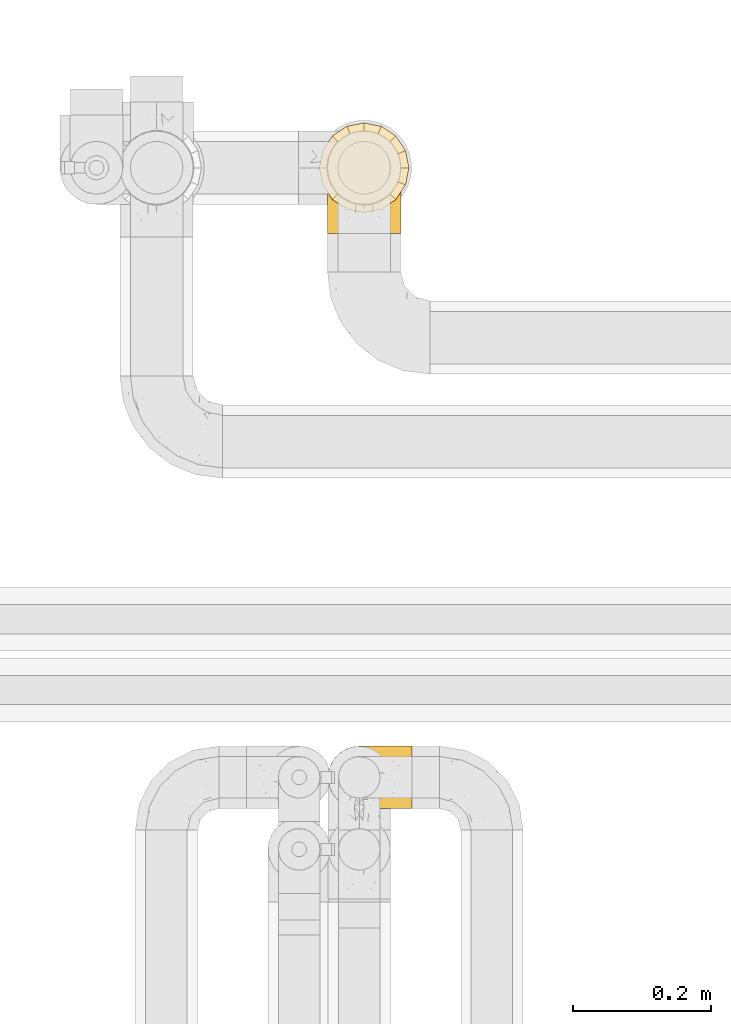
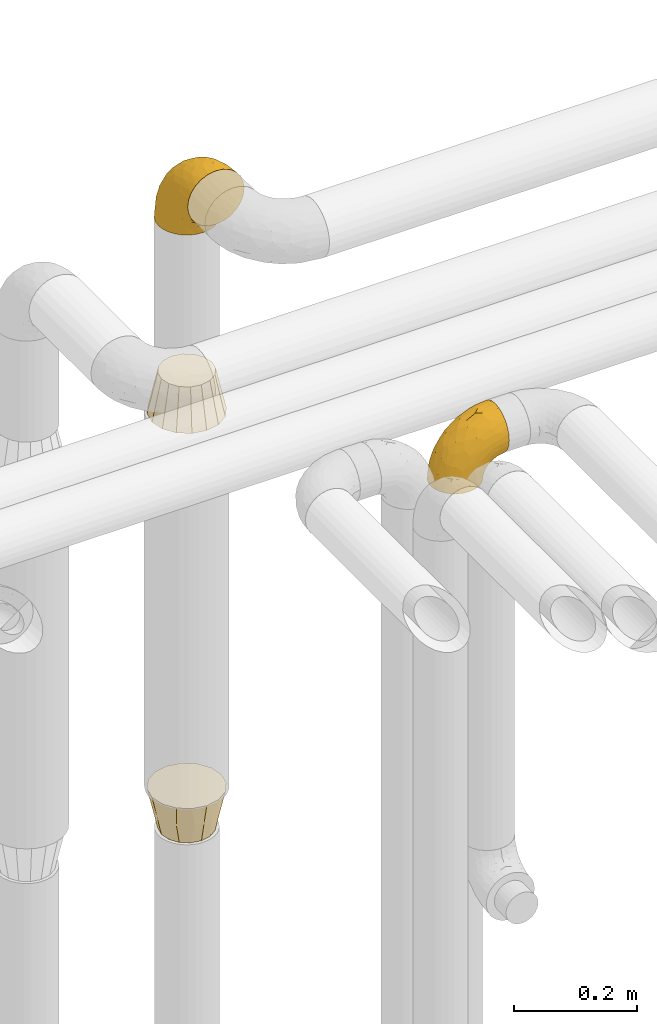
# One storey, part 324 of 827: 4 coverings.
"""IFC2X3 building model written with IfcOpenShell, lengths in millimetres."""

from ifc_helpers import new_model, entity, si_unit, converted_unit, derived_unit, direction, frame, origin, place, context, subcontext, project, spatial, faceted_brep, element, save


model = new_model("IFC2X3")

# Units and contexts
model_context = context("Model", 3, precision=0.01, world=origin(), true_north=direction((6.12303176911189e-17, 1.0)))
body_context = subcontext(model_context, "Body", "Model", "MODEL_VIEW")
ifc_project = project(units=[si_unit("LENGTHUNIT", "METRE", prefix="MILLI"), si_unit("AREAUNIT", "SQUARE_METRE"), si_unit("VOLUMEUNIT", "CUBIC_METRE"), converted_unit("PLANEANGLEUNIT", "DEGREE", entity("IfcRatioMeasure", 0.0174532925199433), si_unit("PLANEANGLEUNIT", "RADIAN"), dimensions=[0, 0, 0, 0, 0, 0, 0]), si_unit("MASSUNIT", "GRAM", prefix="KILO"), derived_unit("MASSDENSITYUNIT", [(si_unit("MASSUNIT", "GRAM", prefix="KILO"), 1), (si_unit("LENGTHUNIT", "METRE"), -3)]), derived_unit("MOMENTOFINERTIAUNIT", [(si_unit("LENGTHUNIT", "METRE"), 4)]), si_unit("TIMEUNIT", "SECOND"), si_unit("FREQUENCYUNIT", "HERTZ"), si_unit("THERMODYNAMICTEMPERATUREUNIT", "DEGREE_CELSIUS"), derived_unit("THERMALTRANSMITTANCEUNIT", [(si_unit("MASSUNIT", "GRAM", prefix="KILO"), 1), (si_unit("THERMODYNAMICTEMPERATUREUNIT", "KELVIN"), -1), (si_unit("TIMEUNIT", "SECOND"), -3)]), derived_unit("VOLUMETRICFLOWRATEUNIT", [(si_unit("LENGTHUNIT", "METRE"), 3), (si_unit("TIMEUNIT", "SECOND"), -1)]), derived_unit("MASSFLOWRATEUNIT", [(si_unit("MASSUNIT", "GRAM", prefix="KILO"), 1), (si_unit("TIMEUNIT", "SECOND"), -1)]), derived_unit("ROTATIONALFREQUENCYUNIT", [(si_unit("TIMEUNIT", "SECOND"), -1)]), si_unit("ELECTRICCURRENTUNIT", "AMPERE"), si_unit("ELECTRICVOLTAGEUNIT", "VOLT"), si_unit("POWERUNIT", "WATT"), si_unit("FORCEUNIT", "NEWTON", prefix="KILO"), si_unit("ILLUMINANCEUNIT", "LUX"), si_unit("LUMINOUSFLUXUNIT", "LUMEN"), si_unit("LUMINOUSINTENSITYUNIT", "CANDELA"), derived_unit("USERDEFINED", [(si_unit("MASSUNIT", "GRAM", prefix="KILO"), -1), (si_unit("LENGTHUNIT", "METRE"), -2), (si_unit("TIMEUNIT", "SECOND"), 3), (si_unit("LUMINOUSFLUXUNIT", "LUMEN"), 1)]), derived_unit("LINEARVELOCITYUNIT", [(si_unit("LENGTHUNIT", "METRE"), 1), (si_unit("TIMEUNIT", "SECOND"), -1)]), si_unit("PRESSUREUNIT", "PASCAL"), derived_unit("USERDEFINED", [(si_unit("LENGTHUNIT", "METRE"), -2), (si_unit("MASSUNIT", "GRAM", prefix="KILO"), 1), (si_unit("TIMEUNIT", "SECOND"), -2)]), derived_unit("LINEARFORCEUNIT", [(si_unit("MASSUNIT", "GRAM", prefix="KILO"), 1), (si_unit("LENGTHUNIT", "METRE"), 1), (si_unit("TIMEUNIT", "SECOND"), -2), (si_unit("LENGTHUNIT", "METRE"), -1)]), derived_unit("PLANARFORCEUNIT", [(si_unit("MASSUNIT", "GRAM", prefix="KILO"), 1), (si_unit("LENGTHUNIT", "METRE"), 1), (si_unit("TIMEUNIT", "SECOND"), -2), (si_unit("LENGTHUNIT", "METRE"), -2)])], contexts=[model_context])

# Site, building, storey
site_placement = place(None, origin())
site = spatial("IfcSite", under=ifc_project, at=site_placement, CompositionType="ELEMENT")
building_placement = place(site_placement, origin())
building = spatial("IfcBuilding", under=site, at=building_placement, CompositionType="ELEMENT")
storey_placement = place(building_placement, frame((0.0, 0.0, 28200.0)))
storey = spatial("IfcBuildingStorey", under=building, at=storey_placement, Name="08", CompositionType="ELEMENT", Elevation=28200.0)

# Coverings
covering_1_placement = place(storey_placement, frame((31701.06, 19256.84, 2903.4)))
element("IfcCovering", 1, at=covering_1_placement, inside=storey, Name=":ADSK_", ObjectType=":ADSK_", PredefinedType="INSULATION", context=body_context, shape_type="Brep", body=[
    faceted_brep([(42.85, 148.32, 1.6), (54.65, 149.65, 1.6), (66.46, 148.31, 1.6), (77.67, 144.39, 1.6), (87.73, 138.06, 1.6), (96.13, 129.66, 1.6), (102.45, 119.6, 1.6), (106.37, 108.39, 1.6), (107.7, 96.6, 1.6), (106.36, 84.79, 1.6), (102.44, 73.57, 1.6), (96.11, 63.51, 1.6), (87.71, 55.11, 1.6), (77.65, 48.79, 1.6), (66.44, 44.87, 1.6), (54.65, 43.55, 1.6), (42.84, 44.88, 1.6), (31.62, 48.8, 1.6), (21.56, 55.13, 1.6), (13.16, 63.53, 1.6), (6.84, 73.59, 1.6), (2.92, 84.8, 1.6), (1.6, 96.6, 1.6), (2.93, 108.41, 1.6), (6.85, 119.62, 1.6), (13.18, 129.68, 1.6), (21.58, 138.08, 1.6), (31.64, 144.4, 1.6), (68.38, 1.6, 45.35), (81.17, 1.6, 50.65), (92.16, 1.6, 59.08), (100.59, 1.6, 70.07), (105.89, 1.6, 82.86), (107.7, 1.6, 96.6), (105.89, 1.6, 110.33), (100.59, 1.6, 123.12), (92.16, 1.6, 134.11), (81.17, 1.6, 142.54), (68.38, 1.6, 147.84), (54.65, 1.6, 149.65), (40.91, 1.6, 147.84), (28.12, 1.6, 142.54), (17.13, 1.6, 134.11), (8.7, 1.6, 123.12), (3.4, 1.6, 110.33), (1.6, 1.6, 96.6), (3.4, 1.6, 82.86), (8.7, 1.6, 70.07), (17.13, 1.6, 59.08), (28.12, 1.6, 50.65), (40.91, 1.6, 45.35), (54.65, 1.6, 43.55), (23.76, 27.97, 137.19), (35.87, 37.09, 141.79), (25.52, 58.27, 128.89), (45.07, 27.13, 146.54), (54.65, 39.91, 144.6), (12.57, 109.11, 69.77), (15.93, 94.41, 94.41), (24.82, 110.94, 87.22), (37.92, 89.69, 117.2), (54.65, 75.62, 129.81), (54.65, 106.28, 106.28), (5.82, 60.12, 101.45), (8.38, 41.41, 115.81), (10.19, 63.22, 109.14), (3.86, 32.05, 107.65), (2.5, 52.13, 93.36), (19.48, 123.27, 59.44), (29.7, 129.32, 63.23), (28.0, 138.3, 35.59), (35.28, 62.95, 132.3), (45.15, 55.89, 138.41), (14.54, 37.4, 126.28), (54.65, 144.6, 39.91), (38.55, 142.66, 37.44), (40.99, 117.85, 90.35), (43.24, 134.01, 65.0), (8.56, 89.25, 85.4), (2.51, 103.34, 26.66), (5.69, 113.52, 29.88), (1.6, 57.43, 78.45), (1.6, 44.19, 85.2), (1.6, 30.95, 91.95), (3.22, 77.98, 77.98), (18.7, 132.66, 29.55), (11.86, 121.52, 41.42), (24.78, 86.93, 111.13), (15.99, 68.4, 114.67), (1.6, 78.45, 57.43), (1.6, 67.94, 67.94), (1.6, 94.53, 14.64), (1.6, 91.95, 30.95), (2.5, 93.36, 52.13), (1.6, 85.2, 44.19), (5.82, 101.45, 60.12), (54.65, 129.81, 75.62), (1.6, 16.27, 94.27), (32.3, 42.46, 24.59), (25.01, 40.4, 34.69), (18.18, 49.71, 31.15), (3.03, 39.4, 75.18), (6.69, 31.26, 67.55), (3.21, 27.7, 79.36), (2.73, 16.7, 84.32), (3.93, 70.67, 40.81), (2.55, 81.69, 29.93), (7.7, 16.68, 70.24), (54.65, 22.57, 37.93), (54.65, 14.26, 40.15), (41.58, 17.68, 42.1), (17.93, 19.58, 55.38), (14.97, 33.49, 52.17), (22.2, 33.01, 44.32), (43.45, 40.69, 19.85), (54.65, 40.15, 14.26), (54.65, 37.93, 22.57), (40.37, 31.04, 34.17), (8.47, 45.29, 54.85), (29.46, 23.55, 44.63), (32.17, 11.36, 47.52), (3.39, 59.1, 59.1), (7.76, 57.42, 44.11), (2.57, 68.96, 53.21), (11.54, 20.38, 62.86), (6.21, 72.46, 20.58), (2.9, 83.66, 15.79), (11.19, 60.66, 27.67), (14.27, 61.01, 13.49), (22.4, 51.85, 18.04), (34.87, 46.07, 12.44), (54.65, 30.25, 30.25), (4.01, 46.65, 66.71), (16.42, 43.0, 42.52), (91.36, 19.58, 55.38), (103.07, 72.44, 20.57), (67.71, 17.67, 42.11), (107.7, 78.45, 57.43), (106.72, 68.97, 53.22), (105.35, 70.65, 40.81), (65.83, 40.69, 19.85), (76.97, 42.45, 24.58), (68.91, 31.04, 34.16), (92.85, 42.99, 42.5), (100.82, 45.18, 54.93), (94.28, 33.46, 52.13), (98.08, 60.64, 27.66), (101.51, 57.37, 44.12), (107.7, 57.43, 78.45), (107.7, 44.19, 85.2), (106.25, 39.35, 75.17), (107.7, 16.27, 94.27), (106.56, 16.7, 84.32), (107.7, 91.95, 30.95), (107.7, 85.2, 44.19), (106.74, 81.68, 29.98), (105.31, 46.68, 66.78), (102.6, 31.26, 67.55), (101.59, 16.68, 70.24), (106.08, 27.7, 79.36), (95.01, 60.99, 13.48), (86.87, 51.84, 18.03), (84.27, 40.41, 34.66), (91.11, 49.72, 31.14), (74.4, 46.06, 12.43), (107.7, 94.53, 14.64), (77.12, 11.35, 47.52), (87.06, 33.02, 44.28), (106.38, 83.65, 15.8), (97.75, 20.38, 62.86), (107.7, 67.94, 67.94), (79.83, 23.53, 44.64), (105.91, 59.12, 59.12), (107.7, 30.95, 91.95), (83.77, 58.27, 128.89), (85.53, 27.97, 137.19), (94.75, 37.4, 126.28), (100.91, 41.41, 115.81), (64.22, 27.21, 146.53), (73.42, 37.09, 141.79), (64.15, 53.2, 139.45), (106.79, 52.13, 93.36), (106.79, 103.34, 26.67), (103.61, 113.5, 29.87), (103.47, 101.45, 60.12), (93.36, 94.41, 94.41), (96.75, 109.08, 69.76), (84.48, 110.95, 87.19), (106.79, 93.36, 52.13), (106.07, 77.98, 77.98), (105.43, 32.05, 107.65), (73.44, 64.63, 131.74), (89.82, 123.25, 59.44), (90.61, 132.65, 29.54), (79.61, 129.32, 63.2), (81.34, 139.96, 27.9), (68.3, 117.85, 90.35), (71.37, 89.69, 117.2), (97.44, 121.51, 41.39), (99.1, 63.23, 109.14), (100.74, 89.17, 85.46), (70.76, 142.66, 37.43), (93.3, 68.4, 114.67), (84.5, 86.94, 111.12), (103.47, 60.12, 101.45), (68.73, 133.2, 65.16)], [[[0, 1, 2, 3, 4, 5, 6, 7, 8, 9, 10, 11, 12, 13, 14, 15, 16, 17, 18, 19, 20, 21, 22, 23, 24, 25, 26, 27]], [[28, 29, 30, 31, 32, 33, 34, 35, 36, 37, 38, 39, 40, 41, 42, 43, 44, 45, 46, 47, 48, 49, 50, 51]], [[52, 53, 54]], [[55, 39, 56]], [[57, 58, 59]], [[60, 61, 62]], [[63, 64, 65]], [[66, 63, 67]], [[68, 69, 70]], [[53, 71, 54]], [[41, 40, 53]], [[53, 72, 71]], [[73, 42, 52]], [[42, 41, 52]], [[74, 0, 75]], [[69, 76, 77]], [[43, 73, 64]], [[45, 44, 66]], [[57, 78, 58]], [[23, 79, 80]], [[67, 81, 82, 83]], [[67, 84, 81]], [[24, 23, 80]], [[25, 85, 26]], [[86, 85, 25]], [[42, 73, 43]], [[0, 27, 75]], [[25, 24, 86]], [[70, 26, 85]], [[0, 74, 1]], [[68, 85, 86]], [[66, 64, 63]], [[60, 59, 87]], [[54, 87, 88]], [[76, 60, 62]], [[84, 89, 90, 81]], [[79, 22, 91, 92]], [[77, 74, 75]], [[93, 92, 94, 89]], [[80, 86, 24]], [[40, 55, 53]], [[76, 59, 60]], [[93, 84, 95]], [[76, 62, 96]], [[55, 72, 53]], [[70, 27, 26]], [[75, 70, 69]], [[78, 84, 63]], [[93, 79, 92]], [[95, 86, 80]], [[77, 76, 96]], [[59, 69, 68]], [[57, 68, 86]], [[68, 57, 59]], [[59, 58, 87]], [[76, 69, 59]], [[88, 87, 58]], [[87, 54, 71]], [[86, 95, 57]], [[78, 57, 95]], [[84, 78, 95]], [[78, 63, 65]], [[58, 78, 65]], [[54, 88, 73]], [[84, 93, 89]], [[79, 95, 80]], [[79, 93, 95]], [[22, 79, 23]], [[66, 83, 97, 45]], [[84, 67, 63]], [[83, 66, 67]], [[64, 44, 43]], [[64, 66, 44]], [[65, 73, 88]], [[53, 52, 41]], [[73, 52, 54]], [[73, 65, 64]], [[65, 88, 58]], [[39, 55, 40]], [[72, 55, 56]], [[56, 61, 72]], [[60, 72, 61]], [[72, 60, 71]], [[87, 71, 60]], [[27, 70, 75]], [[68, 70, 85]], [[74, 77, 96]], [[69, 77, 75]], [[98, 99, 100]], [[46, 45, 97]], [[101, 102, 103]], [[103, 104, 83]], [[105, 94, 106]], [[107, 103, 102]], [[108, 109, 51, 110]], [[111, 112, 113]], [[114, 115, 116]], [[47, 104, 107]], [[110, 117, 108]], [[49, 48, 111]], [[102, 118, 112]], [[119, 120, 111]], [[50, 49, 120]], [[121, 122, 118]], [[105, 123, 89]], [[124, 48, 107]], [[20, 19, 125]], [[121, 81, 90]], [[117, 119, 99]], [[21, 20, 126]], [[22, 21, 91]], [[105, 125, 127]], [[110, 51, 50]], [[19, 128, 125]], [[16, 15, 115]], [[129, 98, 100]], [[126, 91, 21]], [[128, 129, 127]], [[122, 123, 105]], [[114, 117, 98]], [[17, 16, 130]], [[18, 128, 19]], [[129, 18, 17]], [[125, 106, 126]], [[115, 114, 16]], [[130, 129, 17]], [[114, 98, 130]], [[117, 116, 131, 108]], [[99, 119, 113]], [[122, 121, 123]], [[92, 126, 106]], [[105, 127, 122]], [[132, 121, 118]], [[114, 130, 16]], [[129, 130, 98]], [[50, 120, 110]], [[129, 128, 18]], [[125, 128, 127]], [[125, 126, 20]], [[91, 126, 92]], [[105, 89, 94]], [[105, 106, 125]], [[94, 92, 106]], [[100, 122, 127]], [[118, 122, 133]], [[112, 118, 133]], [[132, 118, 102]], [[132, 102, 101]], [[81, 121, 132]], [[82, 103, 83]], [[132, 101, 81]], [[104, 47, 46]], [[124, 107, 102]], [[48, 47, 107]], [[113, 112, 133]], [[112, 111, 124]], [[99, 113, 133]], [[111, 113, 119]], [[99, 133, 100]], [[117, 99, 98]], [[122, 100, 133]], [[127, 129, 100]], [[103, 82, 101]], [[81, 101, 82]], [[112, 124, 102]], [[48, 124, 111]], [[104, 103, 107]], [[46, 97, 104]], [[111, 120, 49]], [[83, 104, 97]], [[110, 120, 119]], [[117, 110, 119]], [[116, 117, 114]], [[89, 123, 90]], [[90, 123, 121]], [[30, 29, 134]], [[11, 10, 135]], [[51, 109, 108, 136]], [[137, 138, 139]], [[140, 141, 142]], [[143, 144, 145]], [[146, 139, 147]], [[148, 149, 150]], [[151, 32, 152]], [[153, 154, 155]], [[156, 150, 157]], [[158, 157, 159]], [[108, 142, 136]], [[31, 158, 152]], [[160, 161, 12]], [[162, 163, 143]], [[140, 142, 116]], [[142, 141, 162]], [[14, 164, 140]], [[14, 140, 115]], [[9, 8, 165]], [[160, 12, 11]], [[141, 164, 161]], [[13, 12, 161]], [[14, 115, 15]], [[28, 166, 29]], [[135, 139, 146]], [[141, 163, 162]], [[135, 146, 160]], [[143, 167, 162]], [[29, 166, 134]], [[116, 142, 108, 131]], [[165, 153, 168]], [[10, 9, 168]], [[168, 135, 10]], [[138, 147, 139]], [[158, 169, 157]], [[14, 13, 164]], [[116, 115, 140]], [[145, 167, 143]], [[135, 160, 11]], [[168, 153, 155]], [[138, 137, 170]], [[157, 144, 156]], [[147, 144, 143]], [[161, 164, 13]], [[140, 164, 141]], [[142, 171, 136]], [[136, 171, 166]], [[161, 160, 146]], [[165, 168, 9]], [[155, 139, 135]], [[139, 154, 137]], [[168, 155, 135]], [[139, 155, 154]], [[144, 147, 172]], [[163, 147, 143]], [[156, 144, 172]], [[157, 169, 145]], [[172, 148, 156]], [[173, 159, 149]], [[159, 157, 150]], [[152, 159, 173]], [[159, 152, 158]], [[31, 30, 158]], [[169, 30, 134]], [[157, 145, 144]], [[167, 134, 171]], [[134, 167, 145]], [[171, 142, 162]], [[162, 167, 171]], [[163, 141, 161]], [[161, 146, 163]], [[147, 163, 146]], [[148, 150, 156]], [[149, 159, 150]], [[30, 169, 158]], [[145, 169, 134]], [[151, 33, 32]], [[31, 152, 32]], [[152, 173, 151]], [[28, 51, 136]], [[134, 166, 171]], [[28, 136, 166]], [[138, 170, 172]], [[147, 138, 172]], [[148, 172, 170]], [[174, 175, 176]], [[35, 34, 177]], [[178, 179, 180]], [[181, 173, 149, 148]], [[182, 183, 184]], [[185, 186, 187]], [[188, 189, 137]], [[190, 33, 151, 173]], [[191, 179, 174]], [[34, 190, 177]], [[39, 38, 178]], [[192, 193, 194]], [[4, 3, 195]], [[175, 179, 37]], [[38, 37, 179]], [[35, 176, 36]], [[196, 62, 197]], [[181, 190, 173]], [[37, 36, 175]], [[183, 6, 198]], [[189, 148, 170, 137]], [[185, 199, 200]], [[3, 2, 201]], [[202, 185, 203]], [[8, 7, 182]], [[200, 184, 186]], [[183, 7, 6]], [[181, 189, 204]], [[200, 189, 184]], [[5, 198, 6]], [[187, 203, 185]], [[195, 3, 201]], [[205, 196, 194]], [[62, 61, 197]], [[186, 198, 192]], [[180, 179, 191]], [[2, 1, 74]], [[198, 193, 192]], [[193, 5, 4]], [[194, 193, 195]], [[2, 74, 201]], [[5, 193, 198]], [[205, 74, 96]], [[188, 137, 154, 153]], [[62, 196, 96]], [[56, 178, 180]], [[198, 184, 183]], [[184, 188, 182]], [[203, 197, 191]], [[205, 194, 201]], [[187, 192, 194]], [[192, 187, 186]], [[194, 196, 187]], [[197, 187, 196]], [[197, 203, 187]], [[202, 174, 176]], [[200, 186, 185]], [[184, 198, 186]], [[199, 185, 202]], [[189, 200, 204]], [[174, 202, 203]], [[176, 177, 199]], [[189, 181, 148]], [[190, 181, 204]], [[190, 204, 177]], [[190, 34, 33]], [[188, 153, 182]], [[189, 188, 184]], [[182, 153, 165, 8]], [[183, 182, 7]], [[199, 177, 204]], [[35, 177, 176]], [[176, 175, 36]], [[179, 175, 174]], [[200, 199, 204]], [[176, 199, 202]], [[203, 191, 174]], [[180, 197, 61]], [[197, 180, 191]], [[61, 56, 180]], [[39, 178, 56]], [[38, 179, 178]], [[194, 195, 201]], [[4, 195, 193]], [[74, 205, 201]], [[96, 196, 205]]]),
])
covering_2_placement = place(storey_placement, frame((31701.92, 18424.46, 2922.4)))
element("IfcCovering", 2, at=covering_2_placement, inside=storey, Name=":ADSK_", ObjectType=":ADSK_", PredefinedType="INSULATION", context=body_context, shape_type="Brep", body=[
    faceted_brep([(36.69, 2.73, 1.6), (27.15, 6.07, 1.6), (18.59, 11.45, 1.6), (11.44, 18.6, 1.6), (6.06, 27.16, 1.6), (2.73, 36.7, 1.6), (1.6, 46.75, 1.6), (2.73, 56.8, 1.6), (6.07, 66.34, 1.6), (11.45, 74.9, 1.6), (18.6, 82.05, 1.6), (27.16, 87.43, 1.6), (36.7, 90.76, 1.6), (46.75, 91.9, 1.6), (56.8, 90.76, 1.6), (66.34, 87.42, 1.6), (74.9, 82.04, 1.6), (82.05, 74.89, 1.6), (87.43, 66.33, 1.6), (90.76, 56.79, 1.6), (91.9, 46.75, 1.6), (90.76, 36.69, 1.6), (87.42, 27.15, 1.6), (82.04, 18.59, 1.6), (74.89, 11.44, 1.6), (66.33, 6.06, 1.6), (56.79, 2.73, 1.6), (46.75, 1.6, 1.6), (122.75, 58.43, 33.98), (122.75, 69.32, 38.49), (122.75, 78.67, 45.67), (122.75, 85.85, 55.02), (122.75, 90.36, 65.91), (122.75, 91.9, 77.6), (122.75, 90.36, 89.28), (122.75, 85.85, 100.17), (122.75, 78.67, 109.52), (122.75, 69.32, 116.7), (122.75, 58.43, 121.21), (122.75, 46.75, 122.75), (122.75, 35.06, 121.21), (122.75, 24.17, 116.7), (122.75, 14.82, 109.52), (122.75, 7.64, 100.17), (122.75, 3.13, 89.28), (122.75, 1.6, 77.6), (122.75, 3.13, 65.91), (122.75, 7.64, 55.02), (122.75, 14.82, 45.67), (122.75, 24.17, 38.49), (122.75, 35.06, 33.98), (122.75, 46.75, 32.45), (24.73, 46.75, 72.81), (29.08, 38.29, 77.17), (38.13, 46.75, 86.21), (85.31, 46.75, 116.82), (93.59, 38.96, 118.49), (100.54, 46.75, 119.23), (63.54, 33.86, 105.14), (38.98, 31.42, 85.37), (50.71, 21.63, 89.33), (93.33, 30.84, 116.14), (75.2, 22.16, 105.06), (100.46, 20.56, 112.15), (41.6, 2.29, 22.95), (80.86, 7.18, 89.91), (94.87, 12.6, 103.39), (67.96, 14.0, 93.6), (52.16, 2.81, 51.41), (52.1, 6.65, 67.71), (36.74, 6.11, 43.53), (17.11, 16.62, 30.91), (23.24, 9.76, 23.58), (29.18, 12.46, 50.07), (52.53, 1.6, 30.68), (60.77, 1.6, 43.01), (69.01, 1.6, 55.34), (100.68, 2.46, 83.48), (103.79, 5.91, 94.96), (16.37, 36.97, 57.29), (7.52, 46.75, 39.03), (7.31, 33.09, 30.66), (93.66, 1.6, 71.81), (102.83, 1.6, 73.63), (112.01, 1.6, 75.46), (18.17, 25.62, 51.57), (71.97, 3.14, 73.13), (9.83, 23.92, 23.16), (5.11, 46.75, 23.8), (45.97, 13.58, 75.6), (48.88, 1.6, 12.33), (50.71, 1.6, 21.51), (22.83, 18.5, 50.46), (51.54, 46.75, 99.61), (81.33, 1.6, 63.57), (31.74, 4.96, 21.26), (32.48, 20.84, 69.54), (68.42, 46.75, 108.21), (25.33, 30.52, 68.42), (16.13, 46.75, 55.92), (92.29, 27.29, 19.36), (94.12, 36.89, 15.76), (100.97, 33.6, 26.13), (95.91, 2.54, 62.78), (107.9, 3.27, 63.65), (87.24, 16.85, 24.34), (95.46, 21.91, 28.46), (90.41, 13.5, 33.53), (74.17, 3.96, 39.46), (83.77, 3.52, 51.05), (76.72, 12.17, 10.94), (84.44, 18.93, 14.55), (76.42, 9.34, 22.21), (90.07, 3.12, 57.05), (99.69, 5.67, 54.0), (61.74, 2.51, 29.19), (58.16, 2.53, 18.85), (112.6, 8.35, 52.84), (110.45, 35.39, 31.47), (107.32, 46.75, 28.31), (108.48, 15.1, 43.0), (66.63, 5.27, 16.9), (115.23, 27.43, 35.98), (105.79, 24.89, 33.91), (89.6, 29.71, 9.97), (69.39, 5.07, 25.93), (66.99, 2.88, 35.61), (102.31, 9.69, 47.45), (99.54, 15.51, 38.26), (55.27, 2.27, 11.7), (82.03, 10.03, 30.13), (94.71, 46.75, 12.12), (96.03, 46.75, 17.02), (94.11, 8.83, 44.39), (84.21, 7.16, 39.83), (101.67, 46.75, 22.67), (112.22, 46.75, 29.63), (108.48, 78.39, 43.0), (102.31, 83.8, 47.45), (99.54, 77.97, 38.26), (94.11, 84.66, 44.38), (110.46, 58.1, 31.47), (76.74, 81.31, 10.93), (50.71, 91.9, 21.51), (58.17, 90.96, 18.84), (55.27, 91.22, 11.7), (94.12, 56.59, 15.76), (92.3, 66.18, 19.36), (100.98, 59.87, 26.14), (69.41, 88.42, 25.94), (76.44, 84.13, 22.21), (66.65, 88.22, 16.9), (115.24, 66.06, 35.98), (102.83, 91.9, 73.63), (112.01, 91.9, 75.46), (82.05, 83.44, 30.12), (87.25, 76.62, 24.33), (112.6, 85.14, 52.84), (107.9, 90.22, 63.65), (93.66, 91.9, 71.81), (95.48, 71.55, 28.45), (89.6, 63.77, 9.97), (60.77, 91.9, 43.01), (69.01, 91.9, 55.34), (74.17, 89.53, 39.46), (48.88, 91.9, 12.33), (84.45, 74.55, 14.54), (95.91, 90.95, 62.78), (90.07, 90.37, 57.05), (81.33, 91.9, 63.57), (61.75, 90.98, 29.2), (83.77, 89.97, 51.05), (84.21, 86.32, 39.81), (52.53, 91.9, 30.68), (90.42, 79.97, 33.52), (67.0, 90.61, 35.61), (99.69, 87.82, 54.0), (105.8, 68.6, 33.91), (94.87, 80.89, 103.39), (80.86, 86.31, 89.91), (67.95, 79.49, 93.6), (75.17, 71.33, 105.05), (50.65, 71.88, 89.27), (71.97, 90.35, 73.13), (52.08, 86.85, 67.67), (32.46, 72.67, 69.49), (38.98, 62.08, 85.36), (103.79, 87.58, 94.96), (100.68, 91.03, 83.48), (63.54, 59.62, 105.14), (93.32, 62.65, 116.13), (93.59, 54.53, 118.49), (100.44, 72.93, 112.15), (52.17, 90.68, 51.41), (36.75, 87.39, 43.51), (41.61, 91.2, 22.95), (7.31, 60.41, 30.66), (17.12, 76.88, 30.91), (16.37, 56.53, 57.3), (23.26, 83.74, 23.58), (18.17, 67.88, 51.56), (25.33, 62.99, 68.41), (9.84, 69.58, 23.16), (29.19, 81.04, 50.07), (22.84, 75.0, 50.45), (31.75, 88.53, 21.25), (45.96, 79.93, 75.56), (29.07, 55.21, 77.16)], [[[0, 1, 2, 3, 4, 5, 6, 7, 8, 9, 10, 11, 12, 13, 14, 15, 16, 17, 18, 19, 20, 21, 22, 23, 24, 25, 26, 27]], [[28, 29, 30, 31, 32, 33, 34, 35, 36, 37, 38, 39, 40, 41, 42, 43, 44, 45, 46, 47, 48, 49, 50, 51]], [[52, 53, 54]], [[55, 56, 57]], [[58, 59, 60]], [[61, 62, 63]], [[27, 64, 0]], [[65, 66, 67]], [[41, 40, 61]], [[68, 69, 70]], [[66, 43, 42]], [[63, 42, 41]], [[71, 72, 73]], [[72, 2, 1]], [[68, 74, 75, 76]], [[45, 44, 77]], [[43, 78, 44]], [[79, 80, 81]], [[77, 82, 83, 84, 45]], [[79, 81, 85]], [[71, 2, 72]], [[65, 86, 77]], [[4, 81, 5]], [[66, 65, 78]], [[4, 3, 87]], [[81, 88, 5]], [[63, 66, 42]], [[68, 70, 64]], [[67, 60, 89]], [[71, 3, 2]], [[64, 27, 90, 91, 74]], [[92, 71, 73]], [[40, 57, 56]], [[59, 93, 54]], [[86, 76, 94, 82]], [[1, 0, 95]], [[58, 62, 61]], [[60, 96, 89]], [[85, 81, 87]], [[56, 97, 58]], [[65, 67, 69]], [[87, 81, 4]], [[67, 89, 69]], [[61, 63, 41]], [[95, 72, 1]], [[73, 72, 70]], [[69, 73, 70]], [[73, 89, 96]], [[3, 71, 87]], [[85, 87, 71]], [[58, 61, 56]], [[59, 58, 93]], [[76, 86, 68]], [[69, 89, 73]], [[68, 86, 69]], [[65, 69, 86]], [[68, 64, 74]], [[95, 64, 70]], [[98, 79, 85]], [[79, 52, 99, 80]], [[66, 62, 67]], [[62, 58, 60]], [[62, 60, 67]], [[59, 98, 96]], [[59, 96, 60]], [[96, 85, 92]], [[88, 81, 80]], [[88, 6, 5]], [[66, 63, 62]], [[64, 95, 0]], [[72, 95, 70]], [[77, 44, 78]], [[86, 82, 77]], [[40, 39, 57]], [[96, 98, 85]], [[40, 56, 61]], [[66, 78, 43]], [[77, 78, 65]], [[79, 98, 53]], [[96, 92, 73]], [[85, 71, 92]], [[97, 56, 55]], [[97, 93, 58]], [[53, 98, 59]], [[54, 53, 59]], [[79, 53, 52]], [[100, 101, 102]], [[46, 45, 84, 83]], [[103, 104, 82]], [[82, 104, 83]], [[105, 106, 107]], [[108, 109, 76]], [[110, 111, 112]], [[103, 113, 114]], [[115, 74, 116]], [[48, 47, 117]], [[118, 102, 119]], [[49, 48, 120]], [[74, 91, 116]], [[116, 121, 115]], [[49, 122, 50]], [[123, 106, 102]], [[124, 111, 22]], [[125, 126, 115]], [[23, 22, 111]], [[24, 110, 121]], [[120, 127, 128]], [[90, 26, 129]], [[27, 26, 90]], [[121, 125, 115]], [[24, 121, 25]], [[130, 105, 107]], [[129, 25, 116]], [[21, 20, 131]], [[120, 123, 122]], [[112, 105, 130]], [[50, 118, 51]], [[21, 124, 22]], [[101, 131, 132]], [[117, 120, 48]], [[24, 23, 110]], [[127, 114, 133]], [[75, 108, 76]], [[107, 134, 130]], [[133, 114, 113]], [[129, 116, 91]], [[25, 121, 116]], [[121, 112, 125]], [[75, 74, 115]], [[101, 135, 102]], [[131, 101, 21]], [[101, 100, 124]], [[128, 127, 133]], [[119, 136, 51, 118]], [[104, 47, 46]], [[83, 104, 46]], [[117, 104, 114]], [[101, 124, 21]], [[111, 124, 100]], [[102, 118, 123]], [[133, 134, 107]], [[111, 110, 23]], [[114, 104, 103]], [[94, 76, 109]], [[121, 110, 112]], [[122, 118, 50]], [[134, 109, 108]], [[133, 107, 128]], [[112, 108, 125]], [[126, 125, 108]], [[108, 75, 126]], [[75, 115, 126]], [[109, 134, 133]], [[130, 108, 112]], [[108, 130, 134]], [[105, 112, 111]], [[111, 100, 105]], [[106, 105, 100]], [[102, 106, 100]], [[128, 106, 123]], [[90, 129, 91]], [[25, 129, 26]], [[104, 117, 47]], [[117, 114, 127]], [[82, 94, 103]], [[113, 94, 109]], [[94, 113, 103]], [[133, 113, 109]], [[106, 128, 107]], [[123, 120, 128]], [[120, 122, 49]], [[118, 122, 123]], [[135, 101, 132]], [[135, 119, 102]], [[117, 127, 120]], [[30, 29, 137]], [[138, 139, 140]], [[51, 136, 119, 141]], [[142, 17, 16]], [[143, 144, 145]], [[146, 147, 148]], [[149, 150, 151]], [[152, 29, 28]], [[33, 32, 153, 154]], [[150, 155, 156]], [[157, 31, 30]], [[153, 158, 159]], [[29, 152, 137]], [[148, 141, 119]], [[156, 160, 147]], [[148, 135, 146]], [[137, 138, 157]], [[19, 161, 146]], [[162, 163, 164]], [[14, 13, 165]], [[153, 32, 158]], [[147, 161, 166]], [[18, 17, 166]], [[167, 168, 169]], [[166, 150, 156]], [[151, 150, 142]], [[151, 170, 149]], [[151, 16, 15]], [[171, 140, 172]], [[165, 143, 145]], [[173, 170, 144]], [[142, 166, 17]], [[19, 131, 20]], [[144, 170, 151]], [[18, 161, 19]], [[173, 144, 143]], [[140, 139, 174]], [[171, 164, 163]], [[164, 172, 155]], [[151, 15, 144]], [[145, 15, 14]], [[173, 162, 170]], [[149, 175, 164]], [[19, 146, 131]], [[132, 131, 146]], [[160, 148, 147]], [[159, 158, 167]], [[135, 132, 146]], [[158, 32, 31]], [[157, 158, 31]], [[167, 158, 176]], [[166, 161, 18]], [[146, 161, 147]], [[148, 177, 141]], [[171, 168, 140]], [[171, 163, 169]], [[151, 142, 16]], [[166, 142, 150]], [[152, 141, 177]], [[51, 141, 28]], [[138, 140, 176]], [[172, 140, 174]], [[175, 149, 170]], [[164, 150, 149]], [[170, 162, 175]], [[162, 164, 175]], [[155, 172, 174]], [[171, 172, 164]], [[155, 174, 156]], [[164, 155, 150]], [[160, 156, 174]], [[147, 166, 156]], [[139, 160, 174]], [[148, 160, 177]], [[15, 145, 144]], [[165, 145, 14]], [[137, 157, 30]], [[158, 157, 176]], [[168, 167, 176]], [[169, 159, 167]], [[140, 168, 176]], [[169, 168, 171]], [[137, 177, 139]], [[160, 139, 177]], [[141, 152, 28]], [[137, 152, 177]], [[148, 119, 135]], [[157, 138, 176]], [[139, 138, 137]], [[178, 179, 180]], [[181, 180, 182]], [[179, 183, 184]], [[185, 186, 182]], [[187, 188, 179]], [[188, 33, 154, 153, 159]], [[181, 189, 190]], [[35, 34, 187]], [[191, 38, 190]], [[192, 178, 181]], [[179, 184, 180]], [[192, 190, 37]], [[37, 190, 38]], [[36, 35, 178]], [[54, 93, 186]], [[35, 187, 178]], [[193, 194, 184]], [[195, 173, 143, 165, 13]], [[195, 193, 173]], [[193, 163, 162, 173]], [[13, 12, 195]], [[8, 7, 196]], [[9, 197, 10]], [[198, 80, 99, 52]], [[196, 7, 88]], [[197, 199, 10]], [[182, 189, 181]], [[200, 198, 201]], [[200, 196, 198]], [[9, 8, 202]], [[194, 199, 203]], [[192, 37, 36]], [[80, 196, 88]], [[183, 159, 169, 163]], [[188, 34, 33]], [[202, 200, 197]], [[185, 203, 204]], [[202, 8, 196]], [[10, 199, 11]], [[12, 11, 205]], [[38, 191, 57]], [[189, 97, 191]], [[203, 199, 197]], [[205, 199, 194]], [[204, 203, 197]], [[184, 203, 206]], [[200, 202, 196]], [[197, 9, 202]], [[207, 54, 186]], [[97, 55, 191]], [[194, 203, 184]], [[183, 163, 193]], [[184, 206, 180]], [[183, 193, 184]], [[205, 195, 12]], [[193, 195, 194]], [[80, 198, 196]], [[207, 186, 201]], [[182, 180, 206]], [[181, 178, 180]], [[185, 182, 206]], [[182, 186, 189]], [[203, 185, 206]], [[185, 200, 201]], [[7, 6, 88]], [[178, 192, 36]], [[190, 192, 181]], [[199, 205, 11]], [[195, 205, 194]], [[159, 183, 188]], [[179, 188, 183]], [[57, 191, 55]], [[57, 39, 38]], [[189, 191, 190]], [[188, 187, 34]], [[178, 187, 179]], [[186, 93, 189]], [[197, 200, 204]], [[185, 204, 200]], [[189, 93, 97]], [[207, 198, 52]], [[185, 201, 186]], [[198, 207, 201]], [[54, 207, 52]]]),
])
covering_3_placement = place(storey_placement, frame((31689.11, 19286.84, 1697.0)))
element("IfcCovering", 3, at=covering_3_placement, inside=storey, Name=":ADSK_", ObjectType=":ADSK_", PredefinedType="INSULATION", context=body_context, shape_type="Brep", body=[
    faceted_brep([(6.54, 91.47, 80.0), (4.07, 79.03, 80.0), (1.6, 66.6, 80.0), (4.13, 53.84, 80.0), (6.54, 41.72, 80.0), (13.59, 31.18, 80.0), (20.63, 20.63, 80.0), (31.18, 13.59, 80.0), (41.72, 6.54, 80.0), (54.16, 4.07, 80.0), (66.6, 1.6, 80.0), (79.36, 4.13, 80.0), (91.47, 6.54, 80.0), (102.01, 13.59, 80.0), (112.56, 20.63, 80.0), (119.6, 31.18, 80.0), (126.65, 41.72, 80.0), (129.12, 54.16, 80.0), (131.6, 66.6, 80.0), (129.06, 79.36, 80.0), (126.65, 91.47, 80.0), (119.6, 102.01, 80.0), (112.56, 112.56, 80.0), (102.01, 119.6, 80.0), (91.47, 126.65, 80.0), (79.03, 129.12, 80.0), (66.6, 131.6, 80.0), (53.84, 129.06, 80.0), (41.72, 126.65, 80.0), (31.18, 119.6, 80.0), (20.63, 112.56, 80.0), (13.59, 102.01, 80.0), (48.62, 22.71, 0.0), (40.92, 27.86, 0.0), (33.21, 33.01, 0.0), (28.06, 40.71, 0.0), (22.91, 48.42, 0.0), (21.11, 57.51, 0.0), (19.3, 66.6, 0.0), (21.15, 75.92, 0.0), (22.91, 84.77, 0.0), (28.06, 92.48, 0.0), (33.21, 100.18, 0.0), (40.92, 105.33, 0.0), (48.62, 110.48, 0.0), (57.71, 112.29, 0.0), (66.8, 114.1, 0.0), (76.12, 112.24, 0.0), (84.98, 110.48, 0.0), (92.68, 105.33, 0.0), (100.39, 100.18, 0.0), (105.53, 92.48, 0.0), (110.68, 84.77, 0.0), (112.49, 75.68, 0.0), (114.3, 66.6, 0.0), (112.44, 57.27, 0.0), (110.68, 48.42, 0.0), (105.53, 40.71, 0.0), (100.39, 33.01, 0.0), (92.68, 27.86, 0.0), (84.98, 22.71, 0.0), (75.89, 20.9, 0.0), (66.8, 19.1, 0.0), (57.48, 20.95, 0.0), (83.16, 12.81, 40.0), (95.69, 18.39, 40.0), (66.7, 10.35, 40.0), (104.65, 25.08, 40.0), (120.48, 50.13, 40.0), (114.9, 37.6, 40.0), (122.95, 66.6, 40.0), (120.48, 83.06, 40.0), (114.9, 95.59, 40.0), (108.21, 104.55, 40.0), (83.16, 120.38, 40.0), (95.69, 114.8, 40.0), (66.7, 122.85, 40.0), (50.23, 120.38, 40.0), (37.71, 114.8, 40.0), (28.75, 108.11, 40.0), (12.91, 83.06, 40.0), (18.49, 95.59, 40.0), (10.45, 66.6, 40.0), (12.91, 50.13, 40.0), (18.49, 37.6, 40.0), (25.18, 28.65, 40.0), (50.23, 12.81, 40.0), (37.71, 18.39, 40.0)], [[[0, 1, 2, 3, 4, 5, 6, 7, 8, 9, 10, 11, 12, 13, 14, 15, 16, 17, 18, 19, 20, 21, 22, 23, 24, 25, 26, 27, 28, 29, 30, 31]], [[32, 33, 34, 35, 36, 37, 38, 39, 40, 41, 42, 43, 44, 45, 46, 47, 48, 49, 50, 51, 52, 53, 54, 55, 56, 57, 58, 59, 60, 61, 62, 63]], [[64, 60, 65]], [[12, 11, 64]], [[61, 64, 66]], [[66, 11, 10]], [[62, 61, 66]], [[12, 64, 65]], [[61, 60, 64]], [[14, 13, 67]], [[68, 16, 69]], [[67, 59, 58]], [[68, 69, 56]], [[17, 68, 70]], [[67, 13, 65]], [[67, 69, 15]], [[68, 56, 55]], [[13, 12, 65]], [[55, 70, 68]], [[65, 60, 59]], [[17, 16, 68]], [[69, 16, 15]], [[67, 57, 69]], [[11, 66, 64]], [[67, 15, 14]], [[57, 56, 69]], [[59, 67, 65]], [[67, 58, 57]], [[70, 55, 54]], [[18, 17, 70]], [[71, 52, 72]], [[20, 19, 71]], [[53, 71, 70]], [[70, 19, 18]], [[54, 53, 70]], [[20, 71, 72]], [[53, 52, 71]], [[22, 21, 73]], [[74, 24, 75]], [[73, 51, 50]], [[74, 75, 48]], [[25, 74, 76]], [[73, 21, 72]], [[73, 75, 23]], [[74, 48, 47]], [[21, 20, 72]], [[47, 76, 74]], [[72, 52, 51]], [[25, 24, 74]], [[75, 24, 23]], [[73, 49, 75]], [[19, 70, 71]], [[73, 23, 22]], [[49, 48, 75]], [[51, 73, 72]], [[73, 50, 49]], [[76, 47, 46]], [[26, 25, 76]], [[77, 44, 78]], [[28, 27, 77]], [[45, 77, 76]], [[76, 27, 26]], [[46, 45, 76]], [[28, 77, 78]], [[45, 44, 77]], [[30, 29, 79]], [[80, 0, 81]], [[79, 43, 42]], [[80, 81, 40]], [[1, 80, 82]], [[79, 29, 78]], [[79, 81, 31]], [[80, 40, 39]], [[29, 28, 78]], [[39, 82, 80]], [[78, 44, 43]], [[1, 0, 80]], [[81, 0, 31]], [[79, 41, 81]], [[27, 76, 77]], [[79, 31, 30]], [[41, 40, 81]], [[43, 79, 78]], [[79, 42, 41]], [[82, 39, 38]], [[2, 1, 82]], [[83, 36, 84]], [[4, 3, 83]], [[37, 83, 82]], [[82, 3, 2]], [[38, 37, 82]], [[4, 83, 84]], [[37, 36, 83]], [[6, 5, 85]], [[86, 8, 87]], [[85, 35, 34]], [[86, 87, 32]], [[9, 86, 66]], [[85, 5, 84]], [[85, 87, 7]], [[86, 32, 63]], [[5, 4, 84]], [[63, 66, 86]], [[84, 36, 35]], [[9, 8, 86]], [[87, 8, 7]], [[85, 33, 87]], [[3, 82, 83]], [[85, 7, 6]], [[33, 32, 87]], [[35, 85, 84]], [[85, 34, 33]], [[66, 63, 62]], [[10, 9, 66]]]),
])
covering_4_placement = place(storey_placement, frame((31689.11, 19286.84, 2520.0)))
element("IfcCovering", 4, at=covering_4_placement, inside=storey, Name=":ADSK_", ObjectType=":ADSK_", PredefinedType="INSULATION", context=body_context, shape_type="Brep", body=[
    faceted_brep([(84.77, 110.48, 80.0), (75.68, 112.29, 80.0), (66.6, 114.1, 80.0), (57.51, 112.29, 80.0), (48.42, 110.48, 80.0), (40.71, 105.33, 80.0), (33.01, 100.18, 80.0), (27.86, 92.48, 80.0), (22.71, 84.77, 80.0), (20.9, 75.68, 80.0), (19.1, 66.6, 80.0), (20.9, 57.51, 80.0), (22.71, 48.42, 80.0), (27.86, 40.71, 80.0), (33.01, 33.01, 80.0), (40.71, 27.86, 80.0), (48.42, 22.71, 80.0), (57.51, 20.9, 80.0), (66.6, 19.1, 80.0), (75.68, 20.9, 80.0), (84.77, 22.71, 80.0), (92.48, 27.86, 80.0), (100.18, 33.01, 80.0), (105.33, 40.71, 80.0), (110.48, 48.42, 80.0), (112.29, 57.51, 80.0), (114.1, 66.6, 80.0), (112.29, 75.68, 80.0), (110.48, 84.77, 80.0), (105.33, 92.48, 80.0), (100.18, 100.18, 80.0), (92.48, 105.33, 80.0), (112.56, 112.56, 0.0), (119.6, 102.01, 0.0), (126.65, 91.47, 0.0), (129.12, 79.03, 0.0), (131.6, 66.6, 0.0), (129.84, 57.76, 0.0), (126.65, 41.72, 0.0), (119.6, 31.18, 0.0), (112.56, 20.63, 0.0), (102.01, 13.59, 0.0), (91.47, 6.54, 0.0), (79.03, 4.07, 0.0), (66.6, 1.6, 0.0), (57.76, 3.35, 0.0), (41.72, 6.54, 0.0), (31.18, 13.59, 0.0), (20.63, 20.63, 0.0), (13.59, 31.18, 0.0), (6.54, 41.72, 0.0), (4.07, 54.16, 0.0), (1.6, 66.6, 0.0), (3.35, 75.43, 0.0), (6.54, 91.47, 0.0), (13.59, 102.01, 0.0), (20.63, 112.56, 0.0), (31.18, 119.6, 0.0), (41.72, 126.65, 0.0), (54.16, 129.12, 0.0), (66.6, 131.6, 0.0), (75.43, 129.84, 0.0), (91.47, 126.65, 0.0), (102.01, 119.6, 0.0)], [[[0, 1, 2, 3, 4, 5, 6, 7, 8, 9, 10, 11, 12, 13, 14, 15, 16, 17, 18, 19, 20, 21, 22, 23, 24, 25, 26, 27, 28, 29, 30, 31]], [[32, 33, 34, 35, 36, 37, 38, 39, 40, 41, 42, 43, 44, 45, 46, 47, 48, 49, 50, 51, 52, 53, 54, 55, 56, 57, 58, 59, 60, 61, 62, 63]], [[46, 45, 44, 18, 17, 16]], [[47, 46, 16, 15, 14, 48]], [[14, 13, 12, 50, 49, 48]], [[10, 52, 51, 50, 12, 11]], [[38, 37, 36, 26, 25, 24]], [[39, 38, 24, 23, 22, 40]], [[22, 21, 20, 42, 41, 40]], [[18, 44, 43, 42, 20, 19]], [[62, 61, 60, 2, 1, 0]], [[63, 62, 0, 31, 30, 32]], [[30, 29, 28, 34, 33, 32]], [[26, 36, 35, 34, 28, 27]], [[54, 53, 52, 10, 9, 8]], [[55, 54, 8, 7, 6, 56]], [[6, 5, 4, 58, 57, 56]], [[2, 60, 59, 58, 4, 3]]]),
])

save(model, "model.ifc")
